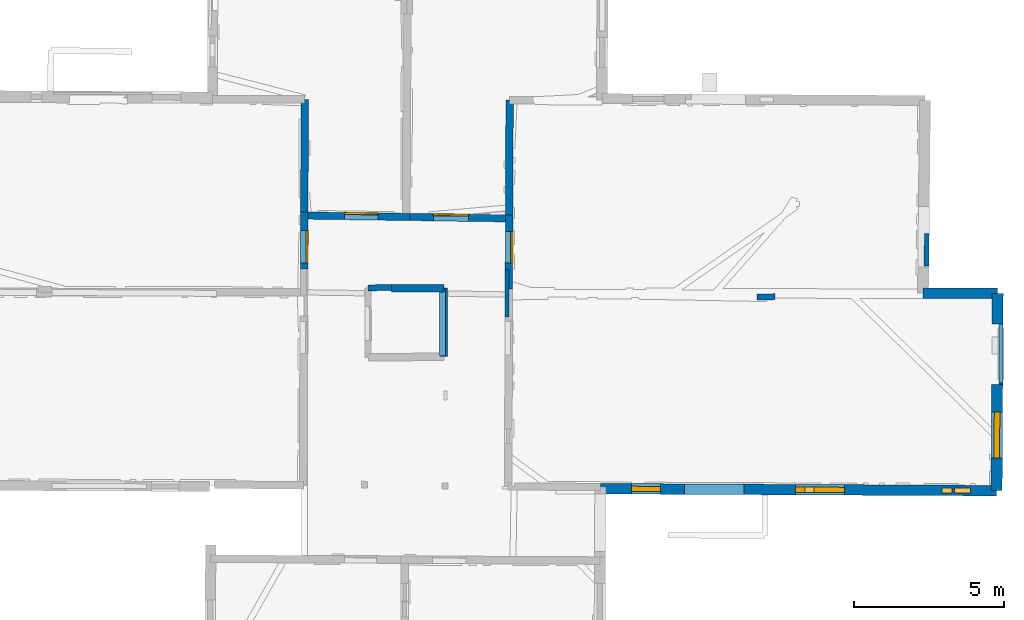
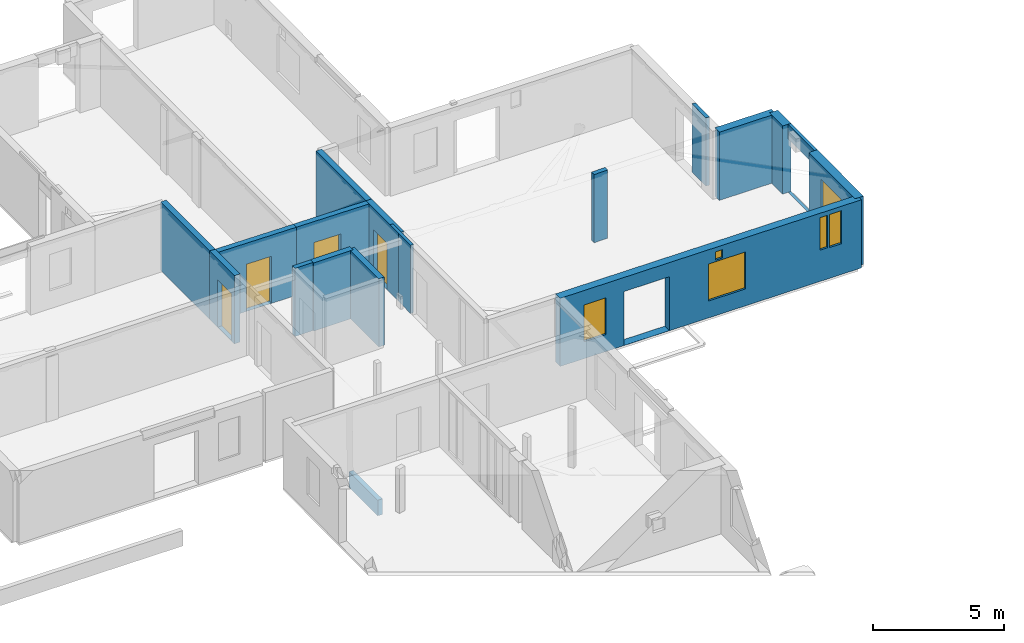
# One storey, part 9 of 17: 18 walls, 6 windows, 4 doors, 12 openings.
"""IFC2X3 building model written with IfcOpenShell, lengths in metres."""

from ifc_helpers import new_model, entity, si_unit, converted_unit, derived_unit, direction, frame, frame_2d, origin, origin_2d_with_axis, place, context, subcontext, project, spatial, polyline, rectangle, outline, extrude, source, transform, mapped, material, layer, layer_set, layer_usage, type_object, type_shapes, element, fill, save


model = new_model("IFC2X3")

# Units and contexts
model_context = context("Model", 3, precision=1e-05, world=origin(), true_north=direction((0.0, 1.0)))
body_context = subcontext(model_context, "Body", "Model", "MODEL_VIEW")
ifc_project = project(units=[si_unit("LENGTHUNIT", "METRE"), si_unit("AREAUNIT", "SQUARE_METRE"), si_unit("VOLUMEUNIT", "CUBIC_METRE"), converted_unit("PLANEANGLEUNIT", "DEGREE", entity("IfcRatioMeasure", 0.0174532925199433), si_unit("PLANEANGLEUNIT", "RADIAN"), dimensions=[0, 0, 0, 0, 0, 0, 0]), si_unit("MASSUNIT", "GRAM", prefix="KILO"), derived_unit("MASSDENSITYUNIT", [(si_unit("MASSUNIT", "GRAM", prefix="KILO"), 1), (si_unit("LENGTHUNIT", "METRE"), -3)]), derived_unit("MOMENTOFINERTIAUNIT", [(si_unit("LENGTHUNIT", "METRE"), 4)]), si_unit("TIMEUNIT", "SECOND"), si_unit("FREQUENCYUNIT", "HERTZ"), si_unit("THERMODYNAMICTEMPERATUREUNIT", "DEGREE_CELSIUS"), derived_unit("THERMALTRANSMITTANCEUNIT", [(si_unit("MASSUNIT", "GRAM", prefix="KILO"), 1), (si_unit("THERMODYNAMICTEMPERATUREUNIT", "KELVIN"), -1), (si_unit("TIMEUNIT", "SECOND"), -3)]), derived_unit("VOLUMETRICFLOWRATEUNIT", [(si_unit("LENGTHUNIT", "METRE"), 3), (si_unit("TIMEUNIT", "SECOND"), -1)]), si_unit("ELECTRICCURRENTUNIT", "AMPERE"), si_unit("ELECTRICVOLTAGEUNIT", "VOLT"), si_unit("POWERUNIT", "WATT"), si_unit("FORCEUNIT", "NEWTON", prefix="KILO"), si_unit("ILLUMINANCEUNIT", "LUX"), si_unit("LUMINOUSFLUXUNIT", "LUMEN"), si_unit("LUMINOUSINTENSITYUNIT", "CANDELA"), derived_unit("USERDEFINED", [(si_unit("MASSUNIT", "GRAM", prefix="KILO"), -1), (si_unit("LENGTHUNIT", "METRE"), -2), (si_unit("TIMEUNIT", "SECOND"), 3), (si_unit("LUMINOUSFLUXUNIT", "LUMEN"), 1)]), derived_unit("LINEARVELOCITYUNIT", [(si_unit("LENGTHUNIT", "METRE"), 1), (si_unit("TIMEUNIT", "SECOND"), -1)]), si_unit("PRESSUREUNIT", "PASCAL"), derived_unit("USERDEFINED", [(si_unit("LENGTHUNIT", "METRE"), -2), (si_unit("MASSUNIT", "GRAM", prefix="KILO"), 1), (si_unit("TIMEUNIT", "SECOND"), -2)]), derived_unit("LINEARFORCEUNIT", [(si_unit("MASSUNIT", "GRAM", prefix="KILO"), 1), (si_unit("LENGTHUNIT", "METRE"), 1), (si_unit("TIMEUNIT", "SECOND"), -2), (si_unit("LENGTHUNIT", "METRE"), -1)]), derived_unit("PLANARFORCEUNIT", [(si_unit("MASSUNIT", "GRAM", prefix="KILO"), 1), (si_unit("LENGTHUNIT", "METRE"), 1), (si_unit("TIMEUNIT", "SECOND"), -2), (si_unit("LENGTHUNIT", "METRE"), -2)])], contexts=[model_context])

# Site, building, storey
placement_1 = place(None, origin())
site = spatial("IfcSite", under=ifc_project, at=placement_1, CompositionType="ELEMENT")
building = spatial("IfcBuilding", under=site, at=placement_1, CompositionType="ELEMENT")
storey_placement = place(placement_1, frame((0.0, 0.0, 5.56662893295288)))
storey = spatial("IfcBuildingStorey", under=building, at=storey_placement, Name="Level 3", CompositionType="ELEMENT", Elevation=5.56662893295288)

# Wall
ifc_material_1 = material(Name="Default wall")
ifc_layer_1 = layer(ifc_material_1, 0.25)
ifc_layer_set_1 = layer_set([ifc_layer_1], Name="wall_thickness_0.2500")
ifc_layer_usage_1 = layer_usage(ifc_layer_set_1, "AXIS2", "POSITIVE", -0.125)
wall_type_1 = type_object("IfcWallType", Name="wall_thickness_0.2500", PredefinedType="STANDARD", material=ifc_layer_set_1)
wall_1_placement = place(storey_placement, frame((9.80435476823003, 64.0455663188033, 0.0), z_axis=(0.0, 0.0, 1.0), x_axis=(-0.00369445753929933, -0.999993175468458, 0.0)))
element("IfcWallStandardCase", 1, at=wall_1_placement, inside=storey, type_object=wall_type_1, material=ifc_layer_usage_1, Name="Wall:1", ObjectType="Wall", context=body_context, shape_type="SweptSolid", body=[
    extrude(outline(polyline([(3.81448297175662, -0.125), (3.81448297175662, 0.125), (0.0, 0.125), (0.0, -0.125), (3.81448297175662, -0.125)])), origin(), (0.0, 0.0, 1.0), 3.16489877700806),
])

# Wall, opening, door
wall_2_placement = place(storey_placement, frame((9.79026232285649, 60.2311093791061, 0.0), z_axis=(0.0, 0.0, 1.0), x_axis=(-0.00369426753813965, -0.999993176170396, 0.0)))
wall_2 = element("IfcWallStandardCase", 2, at=wall_2_placement, inside=storey, type_object=wall_type_1, material=ifc_layer_usage_1, Name="Wall:2", ObjectType="Wall", context=body_context, shape_type="SweptSolid", body=[
    extrude(outline(polyline([(2.47488184788882, -0.125), (2.47488184788882, 0.125), (0.0, 0.125), (0.0, -0.125), (2.47488184788882, -0.125)])), origin(), (0.0, 0.0, 1.0), 3.16489877700806),
])
opening_1_placement = place(wall_2_placement, frame((0.564056395861556, -0.125, 0.00537109375)))
opening_1 = element("IfcOpeningElement", 3, at=opening_1_placement, cuts=wall_2, Name="Opening : 1050 x 2170 : 0", ObjectType="Opening", context=body_context, shape_type="SweptSolid", body=[
    extrude(rectangle(XDim=1.05, YDim=2.17, at=frame_2d((1.085, 0.525), x_axis=(0.0, 1.0))), frame((0.0, 0.0, 0.0), z_axis=(0.0, 1.0, 0.0), x_axis=(0.0, 0.0, 1.0)), (0.0, 0.0, 1.0), 0.25),
])
ifc_material_2 = material(Name="Door Panel")
door_style_1 = type_object("IfcDoorStyle", Name="Door : 1050 x 2170mm", ConstructionType="NOTDEFINED", OperationType="SINGLE_SWING_RIGHT", ParameterTakesPrecedence=False, Sizeable=False, material=ifc_material_2)
shared_shape_1 = source(origin(), body_context, "Body", "SweptSolid", [
    extrude(rectangle(XDim=0.0625, YDim=1.05, at=origin_2d_with_axis()), frame((0.525, 0.21875, 0.0), z_axis=(0.0, 0.0, 1.0), x_axis=(0.0, 1.0, 0.0)), (0.0, 0.0, 1.0), 2.17),
])
type_shapes(door_style_1, [shared_shape_1])
door_1_placement = place(opening_1_placement, origin())
door_1 = element("IfcDoor", 4, at=door_1_placement, inside=storey, type_object=door_style_1, Name="Door : 1050 x 2170mm : 0", ObjectType="Door : 1050 x 2170mm", OverallHeight=2.17, OverallWidth=1.05, context=body_context, shape_type="MappedRepresentation", body=[
    mapped(shared_shape_1, transform((0.0, 0.0, 0.0), scale=1.0)),
])
fill(opening_1, door_1)

# Wall
wall_3_placement = place(storey_placement, frame((2.98448087502072, 64.0738303140019, 0.0), z_axis=(0.0, 0.0, 1.0), x_axis=(-0.00342324934453605, -0.999994140664797, 0.0)))
element("IfcWallStandardCase", 5, at=wall_3_placement, inside=storey, type_object=wall_type_1, material=ifc_layer_usage_1, Name="Wall:8", ObjectType="Wall", context=body_context, shape_type="SweptSolid", body=[
    extrude(outline(polyline([(3.74804594787397, -0.125), (3.74804594787397, 0.125), (0.0, 0.125), (0.0, -0.125), (3.74804594787397, -0.125)])), origin(), (0.0, 0.0, 1.0), 3.16489877700806),
])

# Wall, opening, door
wall_4_placement = place(storey_placement, frame((2.97165037918637, 60.3258063271855, 0.0), z_axis=(0.0, 0.0, 1.0), x_axis=(-0.00342333277580629, -0.999994140379185, 0.0)))
wall_4 = element("IfcWallStandardCase", 6, at=wall_4_placement, inside=storey, type_object=wall_type_1, material=ifc_layer_usage_1, Name="Wall:9", ObjectType="Wall", context=body_context, shape_type="SweptSolid", body=[
    extrude(outline(polyline([(1.89998977091492, -0.125), (1.89998977091492, 0.125), (0.0, 0.125), (0.0, -0.125), (1.89998977091492, -0.125)])), origin(), (0.0, 0.0, 1.0), 3.16489877700806),
])
opening_2_placement = place(wall_4_placement, frame((0.622924633314158, -0.125, 0.00537109375)))
opening_2 = element("IfcOpeningElement", 7, at=opening_2_placement, cuts=wall_4, Name="Opening : 1075 x 2195 : 7", ObjectType="Opening", context=body_context, shape_type="SweptSolid", body=[
    extrude(rectangle(XDim=1.075, YDim=2.195, at=frame_2d((1.0975, 0.5375), x_axis=(0.0, 1.0))), frame((0.0, 0.0, 0.0), z_axis=(0.0, 1.0, 0.0), x_axis=(0.0, 0.0, 1.0)), (0.0, 0.0, 1.0), 0.25),
])
door_style_2 = type_object("IfcDoorStyle", Name="Door : 1075 x 2195mm", ConstructionType="NOTDEFINED", OperationType="SINGLE_SWING_RIGHT", ParameterTakesPrecedence=False, Sizeable=False, material=ifc_material_2)
shared_shape_2 = source(origin(), body_context, "Body", "SweptSolid", [
    extrude(rectangle(XDim=0.0625, YDim=1.075, at=origin_2d_with_axis()), frame((0.5375, 0.21875, 0.0), z_axis=(0.0, 0.0, 1.0), x_axis=(0.0, 1.0, 0.0)), (0.0, 0.0, 1.0), 2.195),
])
type_shapes(door_style_2, [shared_shape_2])
door_2_placement = place(opening_2_placement, origin())
door_2 = element("IfcDoor", 8, at=door_2_placement, inside=storey, type_object=door_style_2, Name="Door : 1075 x 2195mm : 2", ObjectType="Door : 1075 x 2195mm", OverallHeight=2.195, OverallWidth=1.075, context=body_context, shape_type="MappedRepresentation", body=[
    mapped(shared_shape_2, transform((0.0, 0.0, 0.0), scale=1.0)),
])
fill(opening_2, door_2)

# Walls
wall_5_placement = place(storey_placement, frame((5.87770323026642, 57.7824622633899, 0.0), z_axis=(0.0, 0.0, 1.0), x_axis=(0.999993521810305, 0.00359949127266847, 0.0)))
element("IfcWallStandardCase", 9, at=wall_5_placement, inside=storey, type_object=wall_type_1, material=ifc_layer_usage_1, Name="Wall:35", ObjectType="Wall", context=body_context, shape_type="SweptSolid", body=[
    extrude(outline(polyline([(1.74229129330219, -0.125), (1.74229129330219, 0.125), (0.0, 0.125), (0.0, -0.125), (1.74229129330219, -0.125)])), origin(), (0.0, 0.0, 1.0), 3.16489877700806),
])
wall_6_placement = place(storey_placement, frame((7.61998462577665, 57.7887301212651, 0.0), z_axis=(0.0, 0.0, 1.0), x_axis=(-0.000125984264129581, -0.999999992063983, 0.0)))
element("IfcWallStandardCase", 10, at=wall_6_placement, inside=storey, type_object=wall_type_1, material=ifc_layer_usage_1, Name="Wall:61", ObjectType="Wall", context=body_context, shape_type="SweptSolid", body=[
    extrude(outline(polyline([(2.28229143046582, -0.125), (2.28229143046582, 0.125), (0.0, 0.125), (0.0, -0.125), (2.28229143046582, -0.125)])), origin(), (0.0, 0.0, 1.0), 3.16489877700806),
])
ifc_layer_2 = layer(ifc_material_1, 0.349999994039536)
ifc_layer_set_2 = layer_set([ifc_layer_2], Name="wall_thickness_0.3500")
ifc_layer_usage_2 = layer_usage(ifc_layer_set_2, "AXIS2", "POSITIVE", -0.174999997019768)
wall_type_2 = type_object("IfcWallType", Name="wall_thickness_0.3500", PredefinedType="STANDARD", material=ifc_layer_set_2)
wall_7_placement = place(storey_placement, frame((23.5712374784884, 57.6214457413697, 0.0), z_axis=(0.0, 0.0, 1.0), x_axis=(0.999989730259878, -0.00453203869980871, 0.0)))
element("IfcWallStandardCase", 11, at=wall_7_placement, inside=storey, type_object=wall_type_2, material=ifc_layer_usage_2, Name="Wall:5", ObjectType="Wall", context=body_context, shape_type="SweptSolid", body=[
    extrude(outline(polyline([(2.48306726376117, -0.174999997019768), (2.48306726376117, 0.174999997019768), (0.0, 0.174999997019768), (0.0, -0.174999997019768), (2.48306726376117, -0.174999997019768)])), origin(), (0.0, 0.0, 1.0), 3.16489877700806),
])

# Wall, openings, windows
wall_8_placement = place(storey_placement, frame((12.8267011559611, 51.1114373498741, 0.0), z_axis=(0.0, 0.0, 1.0), x_axis=(0.999987647779824, -0.00497034081075699, 0.0)))
wall_8 = element("IfcWallStandardCase", 12, at=wall_8_placement, inside=storey, type_object=wall_type_2, material=ifc_layer_usage_2, Name="Wall:95", ObjectType="Wall", context=body_context, shape_type="SweptSolid", body=[
    extrude(outline(polyline([(13.1916540732298, -0.174999997019768), (13.1916540732298, 0.174999997019768), (0.0, 0.174999997019768), (0.0, -0.174999997019768), (13.1916540732298, -0.174999997019768)])), origin(), (0.0, 0.0, 1.0), 3.16489877700806),
])
opening_3_placement = place(wall_8_placement, frame((2.79668075077064, -0.174999997019768, 0.00537109375)))
element("IfcOpeningElement", 13, at=opening_3_placement, cuts=wall_8, Name="Opening : 1980 x 2505 : 83", ObjectType="Opening", context=body_context, shape_type="SweptSolid", body=[
    extrude(rectangle(XDim=1.98, YDim=2.505, at=frame_2d((1.2525, 0.99), x_axis=(0.0, 1.0))), frame((0.0, 0.0, 0.0), z_axis=(0.0, 1.0, 0.0), x_axis=(0.0, 0.0, 1.0)), (0.0, 0.0, 1.0), 0.349999994039536),
])
opening_4_placement = place(wall_8_placement, frame((11.3740123699711, -0.174999997019768, 1.45237112045288)))
opening_4 = element("IfcOpeningElement", 14, at=opening_4_placement, cuts=wall_8, Name="Opening : 340 x 1510 : 84", ObjectType="Opening", context=body_context, shape_type="SweptSolid", body=[
    extrude(rectangle(XDim=0.34, YDim=1.51, at=frame_2d((0.755, 0.17), x_axis=(0.0, 1.0))), frame((0.0, 0.0, 0.0), z_axis=(0.0, 1.0, 0.0), x_axis=(0.0, 0.0, 1.0)), (0.0, 0.0, 1.0), 0.349999994039536),
])
opening_5_placement = place(wall_8_placement, frame((11.7840134631491, -0.174999997019768, 1.42737102508545)))
opening_5 = element("IfcOpeningElement", 15, at=opening_5_placement, cuts=wall_8, Name="Opening : 535 x 1535 : 85", ObjectType="Opening", context=body_context, shape_type="SweptSolid", body=[
    extrude(rectangle(XDim=0.535, YDim=1.535, at=frame_2d((0.7675, 0.2675), x_axis=(0.0, 1.0))), frame((0.0, 0.0, 0.0), z_axis=(0.0, 1.0, 0.0), x_axis=(0.0, 0.0, 1.0)), (0.0, 0.0, 1.0), 0.349999994039536),
])
opening_6_placement = place(wall_8_placement, frame((1.03668071996525, -0.174999997019768, 0.785370826721191)))
opening_6 = element("IfcOpeningElement", 16, at=opening_6_placement, cuts=wall_8, Name="Opening : 970 x 1710 : 86", ObjectType="Opening", context=body_context, shape_type="SweptSolid", body=[
    extrude(rectangle(XDim=0.97, YDim=1.71, at=frame_2d((0.855, 0.485), x_axis=(0.0, 1.0))), frame((0.0, 0.0, 0.0), z_axis=(0.0, 1.0, 0.0), x_axis=(0.0, 0.0, 1.0)), (0.0, 0.0, 1.0), 0.349999994039536),
])
opening_7_placement = place(wall_8_placement, frame((6.50167970162533, -0.174999997019768, 0.785370826721191)))
opening_7 = element("IfcOpeningElement", 17, at=opening_7_placement, cuts=wall_8, Name="Opening : 1620 x 1720 : 87", ObjectType="Opening", context=body_context, shape_type="SweptSolid", body=[
    extrude(rectangle(XDim=1.62, YDim=1.72, at=frame_2d((0.86, 0.81), x_axis=(0.0, 1.0))), frame((0.0, 0.0, 0.0), z_axis=(0.0, 1.0, 0.0), x_axis=(0.0, 0.0, 1.0)), (0.0, 0.0, 1.0), 0.349999994039536),
])
opening_8_placement = place(wall_8_placement, frame((6.80401345464437, -0.174999997019768, 2.57237100601196)))
opening_8 = element("IfcOpeningElement", 18, at=opening_8_placement, cuts=wall_8, Name="Opening : 310 x 390 : 88", ObjectType="Opening", context=body_context, shape_type="SweptSolid", body=[
    extrude(rectangle(XDim=0.31, YDim=0.39, at=frame_2d((0.195, 0.155), x_axis=(0.0, 1.0))), frame((0.0, 0.0, 0.0), z_axis=(0.0, 1.0, 0.0), x_axis=(0.0, 0.0, 1.0)), (0.0, 0.0, 1.0), 0.349999994039536),
])
ifc_material_3 = material(Name="Window Default")
window_style_1 = type_object("IfcWindowStyle", Name="Window : 340 x 1510mm", ConstructionType="NOTDEFINED", OperationType="NOTDEFINED", ParameterTakesPrecedence=False, Sizeable=False, material=ifc_material_3)
shared_shape_3 = source(origin(), body_context, "Body", "SweptSolid", [
    extrude(rectangle(XDim=0.174999997019768, YDim=0.34, at=origin_2d_with_axis()), frame((0.17, 0.174999997019768, 0.0), z_axis=(0.0, 0.0, 1.0), x_axis=(0.0, 1.0, 0.0)), (0.0, 0.0, 1.0), 1.51),
])
type_shapes(window_style_1, [shared_shape_3])
window_1_placement = place(opening_4_placement, origin())
window_1 = element("IfcWindow", 19, at=window_1_placement, inside=storey, type_object=window_style_1, Name="Window : 340 x 1510mm : 49", ObjectType="Window : 340 x 1510mm", OverallHeight=1.51, OverallWidth=0.34, context=body_context, shape_type="MappedRepresentation", body=[
    mapped(shared_shape_3, transform((0.0, 0.0, 0.0), scale=1.0)),
])
fill(opening_4, window_1)
window_style_2 = type_object("IfcWindowStyle", Name="Window : 535 x 1535mm", ConstructionType="NOTDEFINED", OperationType="NOTDEFINED", ParameterTakesPrecedence=False, Sizeable=False, material=ifc_material_3)
shared_shape_4 = source(origin(), body_context, "Body", "SweptSolid", [
    extrude(rectangle(XDim=0.174999997019768, YDim=0.535, at=origin_2d_with_axis()), frame((0.2675, 0.174999997019768, 0.0), z_axis=(0.0, 0.0, 1.0), x_axis=(0.0, 1.0, 0.0)), (0.0, 0.0, 1.0), 1.535),
])
type_shapes(window_style_2, [shared_shape_4])
window_2_placement = place(opening_5_placement, origin())
window_2 = element("IfcWindow", 20, at=window_2_placement, inside=storey, type_object=window_style_2, Name="Window : 535 x 1535mm : 50", ObjectType="Window : 535 x 1535mm", OverallHeight=1.535, OverallWidth=0.535, context=body_context, shape_type="MappedRepresentation", body=[
    mapped(shared_shape_4, transform((0.0, 0.0, 0.0), scale=1.0)),
])
fill(opening_5, window_2)
window_style_3 = type_object("IfcWindowStyle", Name="Window : 970 x 1710mm", ConstructionType="NOTDEFINED", OperationType="NOTDEFINED", ParameterTakesPrecedence=False, Sizeable=False, material=ifc_material_3)
shared_shape_5 = source(origin(), body_context, "Body", "SweptSolid", [
    extrude(rectangle(XDim=0.174999997019768, YDim=0.97, at=origin_2d_with_axis()), frame((0.485, 0.174999997019768, 0.0), z_axis=(0.0, 0.0, 1.0), x_axis=(0.0, 1.0, 0.0)), (0.0, 0.0, 1.0), 1.71),
])
type_shapes(window_style_3, [shared_shape_5])
window_3_placement = place(opening_6_placement, origin())
window_3 = element("IfcWindow", 21, at=window_3_placement, inside=storey, type_object=window_style_3, Name="Window : 970 x 1710mm : 51", ObjectType="Window : 970 x 1710mm", OverallHeight=1.71, OverallWidth=0.97, context=body_context, shape_type="MappedRepresentation", body=[
    mapped(shared_shape_5, transform((0.0, 0.0, 0.0), scale=1.0)),
])
fill(opening_6, window_3)
window_style_4 = type_object("IfcWindowStyle", Name="Window : 1620 x 1720mm", ConstructionType="NOTDEFINED", OperationType="NOTDEFINED", ParameterTakesPrecedence=False, Sizeable=False, material=ifc_material_3)
shared_shape_6 = source(origin(), body_context, "Body", "SweptSolid", [
    extrude(rectangle(XDim=0.174999997019768, YDim=1.62, at=origin_2d_with_axis()), frame((0.81, 0.174999997019768, 0.0), z_axis=(0.0, 0.0, 1.0), x_axis=(0.0, 1.0, 0.0)), (0.0, 0.0, 1.0), 1.72),
])
type_shapes(window_style_4, [shared_shape_6])
window_4_placement = place(opening_7_placement, origin())
window_4 = element("IfcWindow", 22, at=window_4_placement, inside=storey, type_object=window_style_4, Name="Window : 1620 x 1720mm : 52", ObjectType="Window : 1620 x 1720mm", OverallHeight=1.72, OverallWidth=1.62, context=body_context, shape_type="MappedRepresentation", body=[
    mapped(shared_shape_6, transform((0.0, 0.0, 0.0), scale=1.0)),
])
fill(opening_7, window_4)
window_style_5 = type_object("IfcWindowStyle", Name="Window : 310 x 390mm", ConstructionType="NOTDEFINED", OperationType="NOTDEFINED", ParameterTakesPrecedence=False, Sizeable=False, material=ifc_material_3)
shared_shape_7 = source(origin(), body_context, "Body", "SweptSolid", [
    extrude(rectangle(XDim=0.174999997019768, YDim=0.31, at=origin_2d_with_axis()), frame((0.155, 0.174999997019768, 0.0), z_axis=(0.0, 0.0, 1.0), x_axis=(0.0, 1.0, 0.0)), (0.0, 0.0, 1.0), 0.39),
])
type_shapes(window_style_5, [shared_shape_7])
window_5_placement = place(opening_8_placement, origin())
window_5 = element("IfcWindow", 23, at=window_5_placement, inside=storey, type_object=window_style_5, Name="Window : 310 x 390mm : 53", ObjectType="Window : 310 x 390mm", OverallHeight=0.39, OverallWidth=0.31, context=body_context, shape_type="MappedRepresentation", body=[
    mapped(shared_shape_7, transform((0.0, 0.0, 0.0), scale=1.0)),
])
fill(opening_8, window_5)

# Walls
ifc_layer_3 = layer(ifc_material_1, 0.2)
ifc_layer_set_3 = layer_set([ifc_layer_3], Name="wall_thickness_0.2000")
ifc_layer_usage_3 = layer_usage(ifc_layer_set_3, "AXIS2", "POSITIVE", -0.1)
wall_type_3 = type_object("IfcWallType", Name="wall_thickness_0.2000", PredefinedType="STANDARD", material=ifc_layer_set_3)
wall_9_placement = place(storey_placement, frame((18.6442089081131, 57.502143856761, 0.0), z_axis=(0.0, 0.0, 1.0), x_axis=(-0.999946563215256, -0.0103378292691159, 0.0)))
element("IfcWallStandardCase", 24, at=wall_9_placement, inside=storey, type_object=wall_type_3, material=ifc_layer_usage_3, Name="Wall:15", ObjectType="Wall", context=body_context, shape_type="SweptSolid", body=[
    extrude(outline(polyline([(0.60000001861481, -0.1), (0.60000001861481, 0.1), (0.0, 0.1), (0.0, -0.1), (0.60000001861481, -0.1)])), origin(), (0.0, 0.0, 1.0), 3.16489877700806),
])
wall_10_placement = place(storey_placement, frame((5.08639451153366, 57.7998082045979, 0.0), z_axis=(0.0, 0.0, 1.0), x_axis=(0.999987712095138, 0.00495738426304745, 0.0)))
element("IfcWallStandardCase", 25, at=wall_10_placement, inside=storey, type_object=wall_type_3, material=ifc_layer_usage_3, Name="Wall:109", ObjectType="Wall", context=body_context, shape_type="SweptSolid", body=[
    extrude(outline(polyline([(0.79104394192187, -0.1), (0.79104394192187, 0.1), (0.0, 0.1), (0.0, -0.1), (0.79104394192187, -0.1)])), origin(), (0.0, 0.0, 1.0), 3.16489877700806),
])
placement_2 = place(placement_1, frame((0.0, 0.0, -2.2819995880127)))
wall_11_placement = place(placement_2, frame((7.57413711011124, 57.7368853936777, 0.0), z_axis=(0.0, 0.0, 1.0), x_axis=(-0.0019805338238429, -0.999998038740963, 0.0)))
element("IfcWallStandardCase", 26, at=wall_11_placement, inside=storey, type_object=wall_type_3, material=ifc_layer_usage_3, Name="Wall:846", ObjectType="Wall", context=body_context, shape_type="SweptSolid", body=[
    extrude(outline(polyline([(2.20152714491345, -0.1), (2.20152714491345, 0.1), (0.0, 0.1), (0.0, -0.1), (2.20152714491345, -0.1)])), origin(), (0.0, 0.0, 1.0), 0.720746183395386),
])

# Wall, opening, door
ifc_layer_4 = layer(ifc_material_1, 0.239999994635582)
ifc_layer_set_4 = layer_set([ifc_layer_4], Name="wall_thickness_0.2400")
ifc_layer_usage_4 = layer_usage(ifc_layer_set_4, "AXIS2", "POSITIVE", -0.119999997317791)
wall_type_4 = type_object("IfcWallType", Name="wall_thickness_0.2400", PredefinedType="STANDARD", material=ifc_layer_set_4)
wall_12_placement = place(storey_placement, frame((2.97123846913835, 60.2058134270021, 0.0), z_axis=(0.0, 0.0, 1.0), x_axis=(0.999903581720128, -0.0138862256664131, 0.0)))
wall_12 = element("IfcWallStandardCase", 27, at=wall_12_placement, inside=storey, type_object=wall_type_4, material=ifc_layer_usage_4, Name="Wall:39", ObjectType="Wall", context=body_context, shape_type="SweptSolid", body=[
    extrude(outline(polyline([(3.52124405331025, -0.119999997317791), (3.52124405331025, 0.119999997317791), (0.0, 0.119999997317791), (0.0, -0.119999997317791), (3.52124405331025, -0.119999997317791)])), origin(), (0.0, 0.0, 1.0), 3.16489877700806),
])
opening_9_placement = place(wall_12_placement, frame((1.34206874783053, -0.119999997317791, 0.00537109375)))
opening_9 = element("IfcOpeningElement", 28, at=opening_9_placement, cuts=wall_12, Name="Opening : 1105 x 2185 : 31", ObjectType="Opening", context=body_context, shape_type="SweptSolid", body=[
    extrude(rectangle(XDim=1.105, YDim=2.185, at=frame_2d((1.0925, 0.5525), x_axis=(0.0, 1.0))), frame((0.0, 0.0, 0.0), z_axis=(0.0, 1.0, 0.0), x_axis=(0.0, 0.0, 1.0)), (0.0, 0.0, 1.0), 0.239999994635582),
])
door_style_3 = type_object("IfcDoorStyle", Name="Door : 1105 x 2185mm", ConstructionType="NOTDEFINED", OperationType="SINGLE_SWING_RIGHT", ParameterTakesPrecedence=False, Sizeable=False, material=ifc_material_2)
shared_shape_8 = source(origin(), body_context, "Body", "SweptSolid", [
    extrude(rectangle(XDim=0.0599999986588955, YDim=1.105, at=origin_2d_with_axis()), frame((0.5525, 0.209999995306134, 0.0), z_axis=(0.0, 0.0, 1.0), x_axis=(0.0, 1.0, 0.0)), (0.0, 0.0, 1.0), 2.185),
])
type_shapes(door_style_3, [shared_shape_8])
door_3_placement = place(opening_9_placement, origin())
door_3 = element("IfcDoor", 29, at=door_3_placement, inside=storey, type_object=door_style_3, Name="Door : 1105 x 2185mm : 7", ObjectType="Door : 1105 x 2185mm", OverallHeight=2.185, OverallWidth=1.105, context=body_context, shape_type="MappedRepresentation", body=[
    mapped(shared_shape_8, transform((0.0, 0.0, 0.0), scale=1.0)),
])
fill(opening_9, door_3)

wall_13_placement = place(storey_placement, frame((6.49214301015397, 60.1569166374514, 0.0), z_axis=(0.0, 0.0, 1.0), x_axis=(0.999903570974906, -0.0138869993746138, 0.0)))
wall_13 = element("IfcWallStandardCase", 30, at=wall_13_placement, inside=storey, type_object=wall_type_4, material=ifc_layer_usage_4, Name="Wall:40", ObjectType="Wall", context=body_context, shape_type="SweptSolid", body=[
    extrude(outline(polyline([(3.29799506254874, -0.119999997317791), (3.29799506254874, 0.119999997317791), (0.0, 0.119999997317791), (0.0, -0.119999997317791), (3.29799506254874, -0.119999997317791)])), origin(), (0.0, 0.0, 1.0), 3.16489877700806),
])
opening_10_placement = place(wall_13_placement, frame((0.775802319952433, -0.119999997317791, 0.00537109375)))
opening_10 = element("IfcOpeningElement", 31, at=opening_10_placement, cuts=wall_13, Name="Opening : 1165 x 2185 : 32", ObjectType="Opening", context=body_context, shape_type="SweptSolid", body=[
    extrude(rectangle(XDim=1.165, YDim=2.185, at=frame_2d((1.0925, 0.5825), x_axis=(0.0, 1.0))), frame((0.0, 0.0, 0.0), z_axis=(0.0, 1.0, 0.0), x_axis=(0.0, 0.0, 1.0)), (0.0, 0.0, 1.0), 0.239999994635582),
])
door_style_4 = type_object("IfcDoorStyle", Name="Door : 1165 x 2185mm", ConstructionType="NOTDEFINED", OperationType="SINGLE_SWING_RIGHT", ParameterTakesPrecedence=False, Sizeable=False, material=ifc_material_2)
shared_shape_9 = source(origin(), body_context, "Body", "SweptSolid", [
    extrude(rectangle(XDim=0.0599999986588955, YDim=1.165, at=origin_2d_with_axis()), frame((0.5825, 0.209999995306134, 0.0), z_axis=(0.0, 0.0, 1.0), x_axis=(0.0, 1.0, 0.0)), (0.0, 0.0, 1.0), 2.185),
])
type_shapes(door_style_4, [shared_shape_9])
door_4_placement = place(opening_10_placement, origin())
door_4 = element("IfcDoor", 32, at=door_4_placement, inside=storey, type_object=door_style_4, Name="Door : 1165 x 2185mm : 8", ObjectType="Door : 1165 x 2185mm", OverallHeight=2.185, OverallWidth=1.165, context=body_context, shape_type="MappedRepresentation", body=[
    mapped(shared_shape_9, transform((0.0, 0.0, 0.0), scale=1.0)),
])
fill(opening_10, door_4)

# Walls
ifc_layer_5 = layer(ifc_material_1, 0.159999996423721)
ifc_layer_set_5 = layer_set([ifc_layer_5], Name="wall_thickness_0.1600")
ifc_layer_usage_5 = layer_usage(ifc_layer_set_5, "AXIS2", "POSITIVE", -0.0799999982118607)
wall_type_5 = type_object("IfcWallType", Name="wall_thickness_0.1600", PredefinedType="STANDARD", material=ifc_layer_set_5)
wall_14_placement = place(storey_placement, frame((23.6916670446674, 59.6016594223458, 0.0), z_axis=(0.0, 0.0, 1.0), x_axis=(-0.00789565231672507, -0.999968828851427, 0.0)))
element("IfcWallStandardCase", 33, at=wall_14_placement, inside=storey, type_object=wall_type_5, material=ifc_layer_usage_5, Name="Wall:67", ObjectType="Wall", context=body_context, shape_type="SweptSolid", body=[
    extrude(outline(polyline([(1.0802987193179, -0.0799999982118607), (1.0802987193179, 0.0799999982118607), (0.0, 0.0799999982118607), (0.0, -0.0799999982118607), (1.0802987193179, -0.0799999982118607)])), origin(), (0.0, 0.0, 1.0), 3.16489877700806),
])
ifc_layer_6 = layer(ifc_material_1, 0.129999995231628)
ifc_layer_set_6 = layer_set([ifc_layer_6], Name="wall_thickness_0.1300")
ifc_layer_usage_6 = layer_usage(ifc_layer_set_6, "AXIS2", "POSITIVE", -0.0649999976158142)
wall_type_6 = type_object("IfcWallType", Name="wall_thickness_0.1300", PredefinedType="STANDARD", material=ifc_layer_set_6)
wall_15_placement = place(storey_placement, frame((9.72523950312333, 58.4018251077706, 0.0), z_axis=(0.0, 0.0, 1.0), x_axis=(-0.00587133304612732, -0.999982763575584, 0.0)))
element("IfcWallStandardCase", 34, at=wall_15_placement, inside=storey, type_object=wall_type_6, material=ifc_layer_usage_6, Name="Wall:18", ObjectType="Wall", context=body_context, shape_type="SweptSolid", body=[
    extrude(outline(polyline([(1.57426114342227, -0.0649999976158142), (1.57426114342227, 0.0649999976158142), (0.0, 0.0649999976158142), (0.0, -0.0649999976158142), (1.57426114342227, -0.0649999976158142)])), origin(), (0.0, 0.0, 1.0), 3.16489877700806),
])

# Wall, opening
wall_16_placement = place(storey_placement, frame((26.1648001006192, 56.5975831159234, 0.0), z_axis=(0.0, 0.0, 1.0), x_axis=(0.000458552139576694, -0.999999894864962, 0.0)))
wall_16 = element("IfcWallStandardCase", 35, at=wall_16_placement, inside=storey, type_object=wall_type_6, material=ifc_layer_usage_6, Name="Wall:66", ObjectType="Wall", context=body_context, shape_type="SweptSolid", body=[
    extrude(outline(polyline([(2.01319906419682, -0.0649999976158142), (2.01319906419682, 0.0649999976158142), (0.0, 0.0649999976158142), (0.0, -0.0649999976158142), (2.01319906419682, -0.0649999976158142)])), origin(), (0.0, 0.0, 1.0), 3.16489877700806),
])
opening_11_placement = place(wall_16_placement, frame((-0.013950293070619, -0.0649999976158142, 0.00537109375)))
element("IfcOpeningElement", 36, at=opening_11_placement, cuts=wall_16, Name="Opening : 1985 x 2475 : 64", ObjectType="Opening", context=body_context, shape_type="SweptSolid", body=[
    extrude(rectangle(XDim=1.985, YDim=2.475, at=frame_2d((1.2375, 0.9925), x_axis=(0.0, 1.0))), frame((0.0, 0.0, 0.0), z_axis=(0.0, 1.0, 0.0), x_axis=(0.0, 0.0, 1.0)), (0.0, 0.0, 1.0), 0.129999995231628),
])

# Wall
ifc_layer_7 = layer(ifc_material_1, 0.370000004768372)
ifc_layer_set_7 = layer_set([ifc_layer_7], Name="wall_thickness_0.3700")
ifc_layer_usage_7 = layer_usage(ifc_layer_set_7, "AXIS2", "POSITIVE", -0.185000002384186)
wall_type_7 = type_object("IfcWallType", Name="wall_thickness_0.3700", PredefinedType="STANDARD", material=ifc_layer_set_7)
wall_17_placement = place(storey_placement, frame((26.0542777713841, 57.610193587332, 0.0), z_axis=(0.0, 0.0, 1.0), x_axis=(-0.00549817276226505, -0.999984884933906, 0.0)))
element("IfcWallStandardCase", 37, at=wall_17_placement, inside=storey, type_object=wall_type_7, material=ifc_layer_usage_7, Name="Wall:81", ObjectType="Wall", context=body_context, shape_type="SweptSolid", body=[
    extrude(outline(polyline([(1.01157763747496, -0.185000002384186), (1.01157763747496, 0.185000002384186), (0.0, 0.185000002384186), (0.0, -0.185000002384186), (1.01157763747496, -0.185000002384186)])), origin(), (0.0, 0.0, 1.0), 3.16489877700806),
])

# Wall, opening, window
wall_18_placement = place(storey_placement, frame((26.0376475984108, 54.5854285283191, 0.0), z_axis=(0.0, 0.0, 1.0), x_axis=(-0.00549741874905042, -0.999984889079379, 0.0)))
wall_18 = element("IfcWallStandardCase", 38, at=wall_18_placement, inside=storey, type_object=wall_type_7, material=ifc_layer_usage_7, Name="Wall:82", ObjectType="Wall", context=body_context, shape_type="SweptSolid", body=[
    extrude(outline(polyline([(3.53961952694876, -0.185000002384186), (3.53961952694876, 0.185000002384186), (0.0, 0.185000002384186), (0.0, -0.185000002384186), (3.53961952694876, -0.185000002384186)])), origin(), (0.0, 0.0, 1.0), 3.16489877700806),
])
opening_12_placement = place(wall_18_placement, frame((0.917818468017209, -0.185000002384186, 0.810370922088623)))
opening_12 = element("IfcOpeningElement", 39, at=opening_12_placement, cuts=wall_18, Name="Opening : 1540 x 1685 : 77", ObjectType="Opening", context=body_context, shape_type="SweptSolid", body=[
    extrude(rectangle(XDim=1.54, YDim=1.685, at=frame_2d((0.8425, 0.77), x_axis=(0.0, 1.0))), frame((0.0, 0.0, 0.0), z_axis=(0.0, 1.0, 0.0), x_axis=(0.0, 0.0, 1.0)), (0.0, 0.0, 1.0), 0.370000004768372),
])
window_style_6 = type_object("IfcWindowStyle", Name="Window : 1540 x 1685mm", ConstructionType="NOTDEFINED", OperationType="NOTDEFINED", ParameterTakesPrecedence=False, Sizeable=False, material=ifc_material_3)
shared_shape_10 = source(origin(), body_context, "Body", "SweptSolid", [
    extrude(rectangle(XDim=0.185000002384186, YDim=1.54, at=origin_2d_with_axis()), frame((0.77, 0.185000002384186, 0.0), z_axis=(0.0, 0.0, 1.0), x_axis=(0.0, 1.0, 0.0)), (0.0, 0.0, 1.0), 1.685),
])
type_shapes(window_style_6, [shared_shape_10])
window_6_placement = place(opening_12_placement, origin())
window_6 = element("IfcWindow", 40, at=window_6_placement, inside=storey, type_object=window_style_6, Name="Window : 1540 x 1685mm : 47", ObjectType="Window : 1540 x 1685mm", OverallHeight=1.685, OverallWidth=1.54, context=body_context, shape_type="MappedRepresentation", body=[
    mapped(shared_shape_10, transform((0.0, 0.0, 0.0), scale=1.0)),
])
fill(opening_12, window_6)

save(model, "model.ifc")
